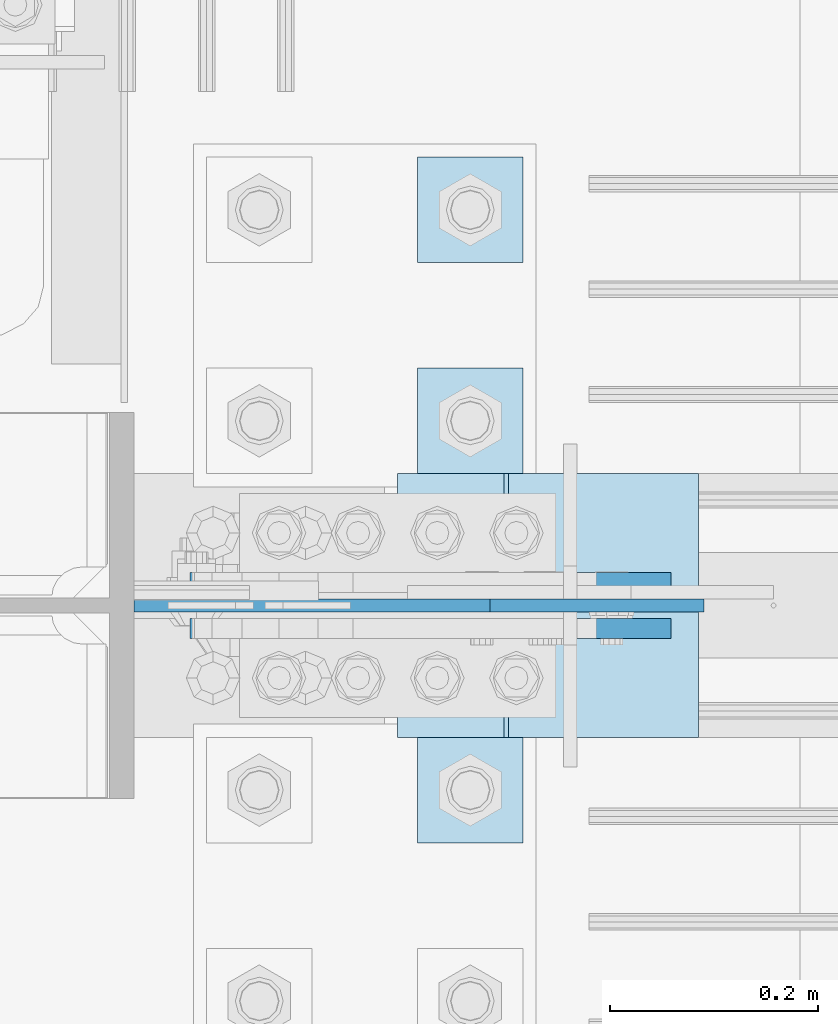
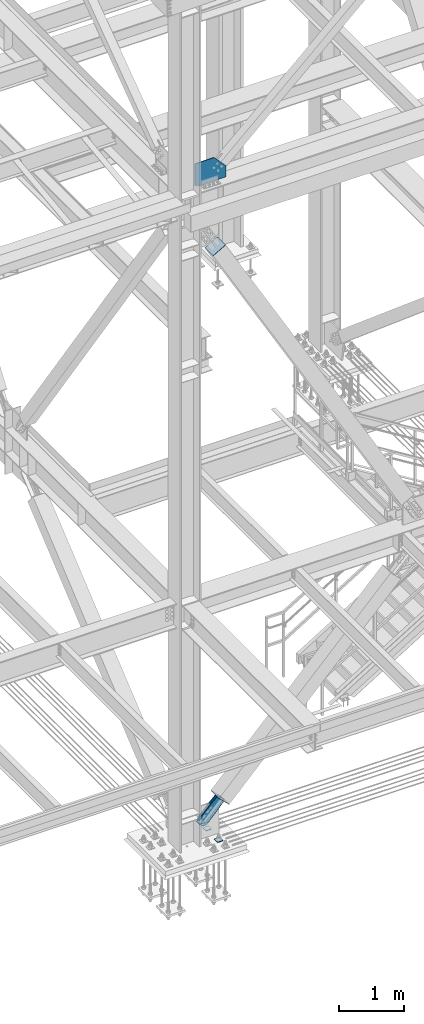
# One storey, part 3545 of 3843: 8 plates, 6 elements without a shape of their own.
"""IFC2X3 building model written with IfcOpenShell, lengths in millimetres."""

from ifc_helpers import new_model, si_unit, frame, origin_with_axes, place, context, subcontext, project, spatial, faceted_brep, material, type_object, element, aggregate, save


model = new_model("IFC2X3")

# Units and contexts
model_context = context("Model", 3, precision=1e-05, world=origin_with_axes())
body_context = subcontext(model_context, "Body", "Model", "MODEL_VIEW")
ifc_project = project(units=[si_unit("LENGTHUNIT", "METRE", prefix="MILLI"), si_unit("AREAUNIT", "SQUARE_METRE"), si_unit("VOLUMEUNIT", "CUBIC_METRE"), si_unit("MASSUNIT", "GRAM", prefix="KILO"), si_unit("TIMEUNIT", "SECOND"), si_unit("PLANEANGLEUNIT", "RADIAN"), si_unit("SOLIDANGLEUNIT", "STERADIAN"), si_unit("THERMODYNAMICTEMPERATUREUNIT", "DEGREE_CELSIUS"), si_unit("LUMINOUSINTENSITYUNIT", "LUMEN")], contexts=[model_context])

# Site, building, storey
site_placement = place(None, origin_with_axes())
site = spatial("IfcSite", under=ifc_project, at=site_placement, CompositionType="ELEMENT")
building_placement = place(site_placement, origin_with_axes())
building = spatial("IfcBuilding", under=site, at=building_placement, Name="Undefined", CompositionType="ELEMENT")
storey_placement = place(building_placement, origin_with_axes())
storey = spatial("IfcBuildingStorey", under=building, at=storey_placement, Name="Undefined", CompositionType="ELEMENT", Elevation=0.0)

# Assembly, plate
assembly_1_placement = place(storey_placement, origin_with_axes())
assembly_1 = element("IfcElementAssembly", 1, at=assembly_1_placement, inside=storey, Name="COLUMN", AssemblyPlace="NOTDEFINED", PredefinedType="RIGID_FRAME")
ifc_material_1 = material(Name="STEEL/A572-50")
plate_type_1 = type_object("IfcPlateType", PredefinedType="NOTDEFINED")
plate_1_placement = place(assembly_1_placement, frame((77196.9500000004, 14998.6999999426, 42481.4999999981), z_axis=(1.0, 0.0, 0.0), x_axis=(0.0, 0.0, 1.0)))
plate_1 = element("IfcPlate", 2, at=plate_1_placement, type_object=plate_type_1, material=ifc_material_1, Name="PLATE", context=body_context, shape_type="Brep", body=[
    faceted_brep([(0.0, -6.35000000000582, 50.7999992361001), (0.0, 6.35000000000582, 50.7999992361001), (12.6999998093161, 6.35000000000582, 50.7999992361001), (12.6999998093161, -6.35000000000582, 50.7999992361001), (17.5600793273625, 6.35000000000582, 49.8332693135162), (17.5600793273625, -6.35000000000582, 49.8332693135162), (21.6802557955161, 6.35000000000582, 47.080255413035), (21.6802557955161, -6.35000000000582, 47.080255413035), (24.43326969599, 6.35000000000582, 42.9600789448741), (24.43326969599, -6.35000000000582, 42.9600789448741), (25.3999996185812, -6.35000000000582, 38.099999426835), (25.3999996185812, 6.35000000000582, 38.099999426835), (25.3999999999942, 6.34999999994034, 2.91038304567337e-11), (25.3999996185303, -6.34999999999491, 2.91038304567337e-11), (3.9945007301867e-09, -6.35000000000036, 548.874981416084), (215.752415321927, -6.35000000000036, 548.874981416084), (215.752415321927, 6.35000000000036, 548.874981416084), (3.9945007301867e-09, 6.35000000000036, 548.874981416084), (440.392120348755, -6.35000000000036, 342.865168725548), (440.392120348755, 6.35000000000036, 342.865168725548), (440.392120302837, -6.35000000000582, 0.0), (440.392120302837, 6.35000000000582, 0.0)], [[[0, 1, 2, 3]], [[3, 2, 4, 5]], [[5, 4, 6, 7]], [[7, 6, 8, 9]], [[10, 11, 12, 13]], [[9, 8, 11, 10]], [[14, 15, 16, 17]], [[15, 18, 19, 16]], [[18, 20, 21, 19]], [[21, 20, 13, 12]], [[6, 4, 2, 1, 17, 16, 19, 21, 12, 11, 8]], [[14, 17, 1, 0]], [[20, 18, 15, 14, 0, 3, 5, 7, 9, 10, 13]]]),
])
aggregate(assembly_1, [plate_1])

# Assembly, plates
assembly_2_placement = place(storey_placement, origin_with_axes())
assembly_2 = element("IfcElementAssembly", 3, at=assembly_2_placement, inside=storey, Name="TEMPLATE", AssemblyPlace="NOTDEFINED", PredefinedType="RIGID_FRAME")
plate_type_2 = type_object("IfcPlateType", PredefinedType="NOTDEFINED")
plate_2_placement = place(assembly_2_placement, frame((77470.0, 14871.7, 30156.15), z_axis=(0.0, -1.0, 0.0), x_axis=(1.0, 0.0, 0.0)))
plate_2 = element("IfcPlate", 4, at=plate_2_placement, type_object=plate_type_2, material=ifc_material_1, Name="Washer Plate", context=body_context, shape_type="Brep", body=[
    faceted_brep([(0.0, -6.3499999046162, 0.0), (-1.67347025126219e-10, -6.35000000000582, 101.600000000151), (-1.67347025126219e-10, 6.35000000000582, 101.600000000151), (7.27595761418343e-12, 6.3499999046162, 0.0), (101.599998474121, -6.34999999999854, 101.599998474121), (101.599998474121, 6.34999999999854, 101.599998474121), (101.6, -6.34999999999854, 0.0), (101.6, 6.34999999999854, 0.0)], [[[0, 1, 2, 3]], [[1, 4, 5, 2]], [[4, 6, 7, 5]], [[6, 0, 3, 7]], [[5, 7, 3, 2]], [[6, 4, 1, 0]]]),
])
plate_3_placement = place(assembly_2_placement, frame((77470.0, 15227.3, 30156.15), z_axis=(0.0, -1.0, 0.0), x_axis=(1.0, 0.0, 0.0)))
plate_3 = element("IfcPlate", 5, at=plate_3_placement, type_object=plate_type_2, material=ifc_material_1, Name="Washer Plate", context=body_context, shape_type="Brep", body=[
    faceted_brep([(0.0, -6.3499999046162, 0.0), (-1.67347025126219e-10, -6.35000000000582, 101.600000000151), (-1.67347025126219e-10, 6.35000000000582, 101.600000000151), (7.27595761418343e-12, 6.3499999046162, 0.0), (101.599998474121, -6.34999999999854, 101.599998474121), (101.599998474121, 6.34999999999854, 101.599998474121), (101.6, -6.34999999999854, 0.0), (101.6, 6.34999999999854, 0.0)], [[[0, 1, 2, 3]], [[1, 4, 5, 2]], [[4, 6, 7, 5]], [[6, 0, 3, 7]], [[5, 7, 3, 2]], [[6, 4, 1, 0]]]),
])
plate_4_placement = place(assembly_2_placement, frame((77470.0, 15430.5, 30156.15), z_axis=(0.0, -1.0, 0.0), x_axis=(1.0, 0.0, 0.0)))
plate_4 = element("IfcPlate", 6, at=plate_4_placement, type_object=plate_type_2, material=ifc_material_1, Name="Washer Plate", context=body_context, shape_type="Brep", body=[
    faceted_brep([(0.0, -6.3499999046162, 0.0), (-1.67347025126219e-10, -6.35000000000582, 101.600000000151), (-1.67347025126219e-10, 6.35000000000582, 101.600000000151), (7.27595761418343e-12, 6.3499999046162, 0.0), (101.599998474121, -6.34999999999854, 101.599998474121), (101.599998474121, 6.34999999999854, 101.599998474121), (101.6, -6.34999999999854, 0.0), (101.6, 6.34999999999854, 0.0)], [[[0, 1, 2, 3]], [[1, 4, 5, 2]], [[4, 6, 7, 5]], [[6, 0, 3, 7]], [[5, 7, 3, 2]], [[6, 4, 1, 0]]]),
])
aggregate(assembly_2, [plate_2, plate_3, plate_4])

# Assembly, plate
assembly_3_placement = place(storey_placement, origin_with_axes())
assembly_3 = element("IfcElementAssembly", 7, at=assembly_3_placement, inside=storey, AssemblyPlace="NOTDEFINED", PredefinedType="RIGID_FRAME")
ifc_material_2 = material(Name="STEEL/A36")
plate_type_3 = type_object("IfcPlateType", PredefinedType="NOTDEFINED")
plate_5_placement = place(assembly_3_placement, frame((77665.5804661109, 15020.925, 30698.0554366591), z_axis=(-0.720244694304652, 0.0, 0.693720102293424), x_axis=(0.693720102293431, 0.0, 0.720244694304645)))
plate_5 = element("IfcPlate", 8, at=plate_5_placement, type_object=plate_type_3, material=ifc_material_2, context=body_context, shape_type="Brep", body=[
    faceted_brep([(0.0, -9.52500000000146, 0.0), (-101.59999999866, -9.52499999999418, -7.01164927375794), (-101.59999999866, 9.52499999999418, -7.01164927375794), (0.0, 9.52500000000146, 0.0), (-364.729297655074, -9.52499999999418, -7.01164927444188), (-364.729297655074, 9.52499999999418, -7.01164927444188), (-401.787405121293, -9.52499999999418, 0.359666612348519), (-401.787405121293, 9.52499999999418, 0.359666612348519), (-433.203751657995, -9.52499999999418, 21.3513982502482), (-433.203751657995, 9.52499999999418, 21.3513982502482), (-454.195483294687, -9.52499999999418, 52.7677447877504), (-454.195483294687, 9.52499999999418, 52.7677447877504), (-461.566799180051, -9.52499999999418, 89.8258492000314), (-461.566799180051, 9.52499999999418, 89.8258492000314), (-454.195483292249, -9.52499999999418, 126.883956664562), (-454.195483292249, 9.52499999999418, 126.883956664562), (-433.203751654662, -9.52499999999418, 158.300303199998), (-433.203751654662, 9.52499999999418, 158.300303199998), (-401.787405118426, -9.52499999999418, 179.292034836384), (-401.787405118426, 9.52499999999418, 179.292034836384), (-364.729299177612, -9.52499999999418, 186.663350722738), (-364.729299177612, 9.52499999999418, 186.663350722738), (-101.5999999907, -9.52499999999418, 186.663350723451), (-101.5999999907, 9.52499999999418, 186.663350723451), (7.37782102078199e-09, -9.52499999999418, 179.651701450231), (7.37782102078199e-09, 9.52499999999418, 179.651701450231), (69.8500000062704, -9.52499999999418, 179.651701450392), (69.8500000062704, 9.52499999999418, 179.651701450392), (69.8499999979995, -9.52499999999418, -4.00177668780088e-10), (69.8499999979995, 9.52499999999418, -4.00177668780088e-10)], [[[0, 1, 2, 3]], [[1, 4, 5, 2]], [[4, 6, 7, 5]], [[6, 8, 9, 7]], [[8, 10, 11, 9]], [[10, 12, 13, 11]], [[12, 14, 15, 13]], [[14, 16, 17, 15]], [[16, 18, 19, 17]], [[18, 20, 21, 19]], [[20, 22, 23, 21]], [[22, 24, 25, 23]], [[24, 26, 27, 25]], [[26, 28, 29, 27]], [[28, 0, 3, 29]], [[5, 7, 9, 11, 13, 15, 17, 19, 21, 23, 25, 27, 29, 3, 2]], [[28, 26, 24, 22, 20, 18, 16, 14, 12, 10, 8, 6, 4, 1, 0]]]),
])
aggregate(assembly_3, [plate_5])

assembly_4_placement = place(storey_placement, origin_with_axes())
assembly_4 = element("IfcElementAssembly", 9, at=assembly_4_placement, inside=storey, AssemblyPlace="NOTDEFINED", PredefinedType="RIGID_FRAME")
plate_6_placement = place(assembly_4_placement, frame((77665.5804661109, 14976.475, 30698.0554366591), z_axis=(-0.720244694304652, 0.0, 0.693720102293424), x_axis=(0.693720102293431, 0.0, 0.720244694304645)))
plate_6 = element("IfcPlate", 10, at=plate_6_placement, type_object=plate_type_3, material=ifc_material_2, context=body_context, shape_type="Brep", body=[
    faceted_brep([(0.0, -9.52500000000146, 0.0), (-101.59999999866, -9.52499999999418, -7.01164927375794), (-101.59999999866, 9.52499999999418, -7.01164927375794), (0.0, 9.52500000000146, 0.0), (-364.729297655074, -9.52499999999418, -7.01164927444188), (-364.729297655074, 9.52499999999418, -7.01164927444188), (-401.787405121293, -9.52499999999418, 0.359666612348519), (-401.787405121293, 9.52499999999418, 0.359666612348519), (-433.203751657995, -9.52499999999418, 21.3513982502482), (-433.203751657995, 9.52499999999418, 21.3513982502482), (-454.195483294687, -9.52499999999418, 52.7677447877504), (-454.195483294687, 9.52499999999418, 52.7677447877504), (-461.566799180051, -9.52499999999418, 89.8258492000314), (-461.566799180051, 9.52499999999418, 89.8258492000314), (-454.195483292249, -9.52499999999418, 126.883956664562), (-454.195483292249, 9.52499999999418, 126.883956664562), (-433.203751654662, -9.52499999999418, 158.300303199998), (-433.203751654662, 9.52499999999418, 158.300303199998), (-401.787405118426, -9.52499999999418, 179.292034836384), (-401.787405118426, 9.52499999999418, 179.292034836384), (-364.729299177612, -9.52499999999418, 186.663350722738), (-364.729299177612, 9.52499999999418, 186.663350722738), (-101.5999999907, -9.52499999999418, 186.663350723451), (-101.5999999907, 9.52499999999418, 186.663350723451), (7.37782102078199e-09, -9.52499999999418, 179.651701450231), (7.37782102078199e-09, 9.52499999999418, 179.651701450231), (69.8500000062704, -9.52499999999418, 179.651701450392), (69.8500000062704, 9.52499999999418, 179.651701450392), (69.8499999979995, -9.52499999999418, -4.00177668780088e-10), (69.8499999979995, 9.52499999999418, -4.00177668780088e-10)], [[[0, 1, 2, 3]], [[1, 4, 5, 2]], [[4, 6, 7, 5]], [[6, 8, 9, 7]], [[8, 10, 11, 9]], [[10, 12, 13, 11]], [[12, 14, 15, 13]], [[14, 16, 17, 15]], [[16, 18, 19, 17]], [[18, 20, 21, 19]], [[20, 22, 23, 21]], [[22, 24, 25, 23]], [[24, 26, 27, 25]], [[26, 28, 29, 27]], [[28, 0, 3, 29]], [[5, 7, 9, 11, 13, 15, 17, 19, 21, 23, 25, 27, 29, 3, 2]], [[28, 26, 24, 22, 20, 18, 16, 14, 12, 10, 8, 6, 4, 1, 0]]]),
])
aggregate(assembly_4, [plate_6])

assembly_5_placement = place(storey_placement, origin_with_axes())
assembly_5 = element("IfcElementAssembly", 11, at=assembly_5_placement, inside=storey, Name="Plate", AssemblyPlace="NOTDEFINED", PredefinedType="RIGID_FRAME")
plate_type_4 = type_object("IfcPlateType", PredefinedType="NOTDEFINED")
plate_7_placement = place(assembly_5_placement, frame((77738.6087377631, 14871.7, 30720.2892969722), z_axis=(-0.720244694304652, 0.0, 0.693720102293424), x_axis=(0.0, 1.0, 0.0)))
plate_7 = element("IfcPlate", 12, at=plate_7_placement, type_object=plate_type_4, material=ifc_material_2, Name="Plate", context=body_context, shape_type="Brep", body=[
    faceted_brep([(0.0, -3.17499999999927, 0.0), (0.0, -3.17499999965185, 254.000000005151), (0.0, 3.17500000035216, 254.000000005166), (0.0, 3.17499999999927, 0.0), (254.0, -3.17499999965185, 254.000000005151), (254.0, 3.17500000035216, 254.000000005166), (254.0, -3.17500000000291, 0.0), (254.0, 3.17499999999927, 1.45519152283669e-11)], [[[0, 1, 2, 3]], [[1, 4, 5, 2]], [[4, 6, 7, 5]], [[6, 0, 3, 7]], [[5, 7, 3, 2]], [[6, 4, 1, 0]]]),
])
aggregate(assembly_5, [plate_7])

assembly_6_placement = place(storey_placement, origin_with_axes())
assembly_6 = element("IfcElementAssembly", 13, at=assembly_6_placement, inside=storey, Name="Plate", AssemblyPlace="NOTDEFINED", PredefinedType="RIGID_FRAME")
plate_8_placement = place(assembly_6_placement, frame((77452.3615910184, 15125.7, 41171.1172960143), z_axis=(0.868467373134175, 0.0, 0.495746328076595), x_axis=(0.0, -1.0, 0.0)))
plate_8 = element("IfcPlate", 14, at=plate_8_placement, type_object=plate_type_4, material=ifc_material_2, Name="Plate", context=body_context, shape_type="Brep", body=[
    faceted_brep([(0.0, -3.17499999999927, 0.0), (0.0, -3.17499999965185, 254.000000005151), (0.0, 3.17500000035216, 254.000000005166), (0.0, 3.17499999999927, 0.0), (254.0, -3.17499999965185, 254.000000005151), (254.0, 3.17500000035216, 254.000000005166), (254.0, -3.17500000000291, 0.0), (254.0, 3.17499999999927, 1.45519152283669e-11)], [[[0, 1, 2, 3]], [[1, 4, 5, 2]], [[4, 6, 7, 5]], [[6, 0, 3, 7]], [[5, 7, 3, 2]], [[6, 4, 1, 0]]]),
])
aggregate(assembly_6, [plate_8])

save(model, "model.ifc")
